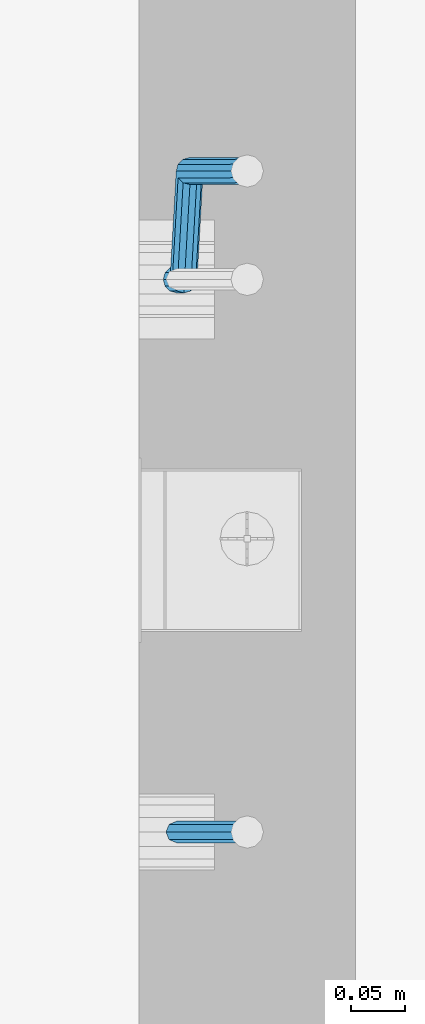
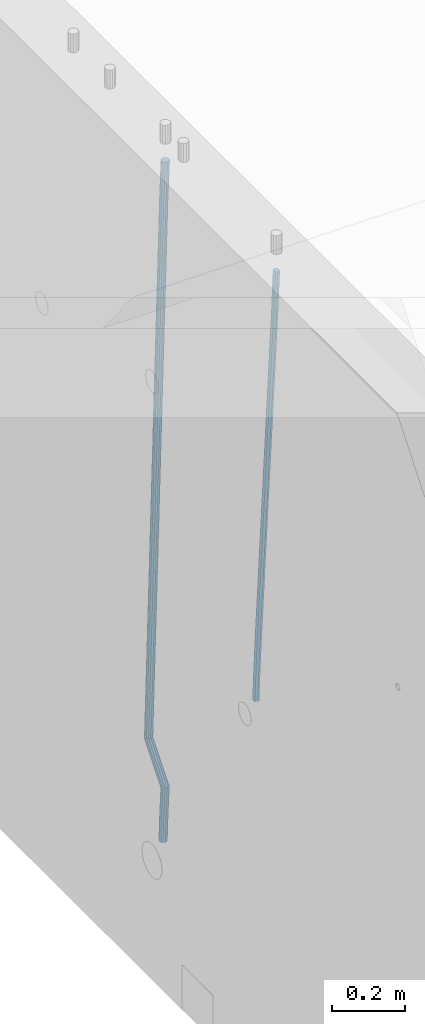
# One storey, part 103 of 350: 2 beams, 1 element without a shape of its own.
"""IFC2X3 building model written with IfcOpenShell, lengths in millimetres."""

from ifc_helpers import new_model, si_unit, frame, origin_with_axes, place, context, subcontext, project, spatial, faceted_brep, material, type_object, element, aggregate, save


model = new_model("IFC2X3")

# Units and contexts
model_context = context("Model", 3, precision=1e-05, world=origin_with_axes())
body_context = subcontext(model_context, "Body", "Model", "MODEL_VIEW")
ifc_project = project(units=[si_unit("LENGTHUNIT", "METRE", prefix="MILLI"), si_unit("AREAUNIT", "SQUARE_METRE"), si_unit("VOLUMEUNIT", "CUBIC_METRE"), si_unit("MASSUNIT", "GRAM", prefix="KILO"), si_unit("TIMEUNIT", "SECOND"), si_unit("PLANEANGLEUNIT", "RADIAN"), si_unit("SOLIDANGLEUNIT", "STERADIAN"), si_unit("THERMODYNAMICTEMPERATUREUNIT", "DEGREE_CELSIUS"), si_unit("LUMINOUSINTENSITYUNIT", "LUMEN")], contexts=[model_context])

# Site, building, storey
site_placement = place(None, origin_with_axes())
site = spatial("IfcSite", under=ifc_project, at=site_placement, CompositionType="ELEMENT")
building_placement = place(site_placement, origin_with_axes())
building = spatial("IfcBuilding", under=site, at=building_placement, CompositionType="ELEMENT")
storey_placement = place(building_placement, origin_with_axes())
storey = spatial("IfcBuildingStorey", under=building, at=storey_placement, Name="2", CompositionType="ELEMENT", Elevation=0.0)

# Assembly, beams
assembly_placement = place(storey_placement, origin_with_axes())
assembly = element("IfcElementAssembly", 1, at=assembly_placement, inside=storey, AssemblyPlace="NOTDEFINED", PredefinedType="REINFORCEMENT_UNIT")
ifc_material = material()
beam_type_1 = type_object("IfcBeamType", Name="D20", PredefinedType="NOTDEFINED")
beam_1_placement = place(assembly_placement, frame((21744.9999977209, 9994.99999999607, 85990.0), z_axis=(0.999642804629538, 0.000205762999925497, -0.0267249099901003), x_axis=(0.0267249109941254, -4.30000210532798e-08, 0.999642825779465)))
beam_1 = element("IfcBeam", 2, at=beam_1_placement, type_object=beam_type_1, material=ifc_material, Name="JM20", ObjectType="D20", context=body_context, shape_type="Brep", body=[
    faceted_brep([(0.0, -10.0, 0.0), (-4.19531716033816e-08, -7.07106781186667, -7.07106781187031), (60.4266690400545, -7.0710677960451, -7.07106780570757), (60.4266690441291, -9.99999998418934, 6.15546014159918e-09), (0.0, 0.0, -10.0), (60.426669036824, 1.58106558956206e-08, -9.99999999384454), (4.196772351861e-08, 7.07106781186303, -7.07106781186667), (60.4266690363438, 7.07106782768096, -7.07106780570757), (0.0, 10.0, 0.0), (60.4266690388904, 10.0000000158179, 6.15182216279209e-09), (4.196772351861e-08, 7.07106781185939, 7.07106781185939), (60.4266690429649, 7.07106782768096, 7.07106781802577), (0.0, 0.0, 10.0), (60.4266690461809, 1.58179318532348e-08, 10.0000000061555), (-4.19531716033816e-08, -7.07106781187031, 7.07106781185939), (60.4266690466611, -7.07106779605238, 7.07106781802213), (61.0378400410118, -7.07106779588503, -7.07106780564936), (60.991799419251, -9.99999998403655, 6.21366780251265e-09), (61.0569027789461, 1.5985278878361e-08, -9.99999999378269), (61.0378209396877, 7.07106782784831, -7.07106780564936), (60.9917724058905, 10.0000000159635, 6.21366780251265e-09), (60.9457317841297, 7.07106782781193, 7.0710678180767), (60.9266690461809, 1.59488990902901e-08, 10.0000000062028), (60.9457508854539, -7.07106779591413, 7.0710678180767), (61.6489592143771, -7.07106614513759, -7.06310863441468), (61.5568818710308, -9.9999984576425, 0.00735959856683621), (61.6870830769039, 1.71821739058942e-06, -9.99179257185824), (61.6489210170112, 7.07106947854481, -7.06310888312146), (61.556827851804, 10.0000015422847, 0.00735924683976918), (61.4647505084577, 7.07106922979438, 7.07782747982128), (61.4266266459163, 1.36643211590126e-06, 10.0065114172685), (61.464788705809, -7.07106639389531, 7.07782772852806), (176.543135720174, -7.07075579406956, -5.56673531796696), (176.451058376813, -9.99968810657447, 1.50373291501455), (176.581259582701, 0.000312069292704109, -8.49541925541052), (176.543097522794, 7.07137982961285, -5.56673556667374), (176.451004357587, 10.00031189336, 1.50373256329476), (176.35892701424, 7.07137958085514, 8.57420079627263), (176.320803151699, 0.000311717507429421, 11.5028847337162), (176.358965211621, -7.07075604281999, 8.57420104497578), (177.098753836006, -7.07075429323595, -5.55949898843028), (176.98362511232, -9.99968666800123, 1.510669025065), (177.146421932586, 0.000313595905026887, -8.48805862247536), (177.098706077581, 7.07138133041735, -5.55949936166144), (176.983557571715, 10.0003133318824, 1.51066849724157), (176.868428848029, 7.07138095712435, 8.58083651073321), (176.820760751449, 0.000313067976094317, 11.5093961447819), (176.868476606425, -7.07075466652896, 8.58083688396073), (177.654312950661, -7.07075204110879, -5.54863964998367), (177.516135294456, -9.99968450931192, 1.52107783331303), (177.711524267797, 0.000315886711177882, -8.47701274570863), (177.654255632195, 7.07138358250813, -5.54864021007961), (177.516054233929, 10.0003154905207, 1.5210770412159), (177.377876577739, 7.0713830223176, 8.59079452451624), (177.320665260588, 0.000315094497636892, 11.5191676202448), (177.377933896176, -7.07075260129932, 8.59079508461218), (299.599458226279, -7.07025770011387, -3.16501643125957), (299.461280570089, -9.99919016831518, 3.90470105203713), (299.65666954343, 0.000810227711554035, -6.09338952698454), (299.599400907857, 7.07187792350123, -3.16501699135551), (299.461199509577, 10.0008098315193, 3.90470025994), (299.323021853372, 7.07187736331798, 10.9744177432367), (299.265810536235, 0.000809435492556077, 13.9027908389617), (299.323079171809, -7.07025826029712, 10.9744183033363), (300.117505425049, -7.07025560005422, -3.15489032637561), (299.971788958996, -9.99918809853989, 3.91467979818117), (300.177827776904, 0.000812340382253751, -6.0832026116841), (300.117445104319, 7.07188002354815, -3.15489094515215), (299.971753863239, 10.0008119014747, 3.91467990454839), (299.826037397244, 7.07187940244148, 10.9842500291161), (299.765715045374, 0.000811462005003705, 13.9125623144282), (299.826097717974, -7.07025622116089, 10.9842506478926), (300.635529927473, -7.07025328000054, -3.14366299205358), (300.482325191449, -9.99918581231213, 3.92574478310053), (300.69896317774, 0.000814674367575208, -6.07190785373314), (300.635466604566, 7.07188234358546, -3.14366367590264), (300.482235639342, 10.000814187486, 3.92574381599843), (300.329030903304, 7.07188165517618, 10.9951515911598), (300.265597653051, 0.000813700806247653, 13.9233964528321), (300.329094226225, -7.07025396841345, 10.9951522750052), (1294.72134140272, -7.06580111335825, 18.4015220180045), (1294.5681366667, -9.99473364566802, 25.4709297931586), (1294.78477465297, 0.00526684101168939, 15.4732771563286), (1294.7212780798, 7.07633451023139, 18.4015213341554), (1294.56804711456, 10.0052663541301, 25.4709288260528), (1294.41484237854, 7.07633382181848, 32.5403366012142), (1294.35140912827, 0.00526586744854285, 35.4685814628901), (1294.41490570146, -7.06580180177116, 32.5403372850597), (1295.22122401037, -7.065798874557, 18.4123561564047), (1295.07847764336, -9.99473136002962, 25.4819905996155), (1295.31851894651, 0.00526923146571789, 15.4848451914186), (1295.31336839774, 7.07633716199962, 18.4143539239521), (1295.20878948565, 10.005269223795, 25.4848158695786), (1295.06604311864, 7.07633673832242, 32.5544503127894), (1294.96874818249, 0.00526863229970331, 35.4819612777756), (1294.97389873129, -7.0657992982342, 32.5524525452383), (1295.72113723878, -7.07231784537726, 18.4190095076701), (1295.5888498814, -10.0013867184771, 25.4887831499691), (1295.85229593501, -0.00169132971677755, 15.4919492358822), (1295.90549498468, 7.06861571010995, 18.4222345439302), (1295.84957110598, 9.99691330030873, 25.4933440399909), (1295.71728374861, 7.06784442721073, 32.5631176822862), (1295.58612505237, -0.00278208844792971, 35.4901779540742), (1295.53292600272, -7.07308912827466, 32.5598926460261), (1317.55191410908, -7.35699564410061, 18.7095555837295), (1317.41962675171, -10.2860645171968, 25.7793292260321), (1317.68307280532, -0.28636912843649, 15.7824953119416), (1317.73627185497, 6.7839379113866, 18.7127806199969), (1317.68034797629, 9.71223550158902, 25.783890116054), (1317.54806061891, 6.7831666284892, 32.8536637583529), (1317.41690192268, -0.2874598871731, 35.7807240301408), (1317.363702873, -7.35776692699619, 32.8504387220928), (1318.18734857353, -7.36528183957671, 18.7180125887826), (1318.07971594617, -10.2946722153993, 25.7881143611849), (1318.26138049197, -0.293910379039517, 15.7901920160075), (1318.25844480767, 6.77712866920592, 18.7197302261993), (1318.18026120469, 9.70571653076877, 25.7905434673194), (1318.07262857731, 6.7763261549444, 32.8606452397216), (1317.99859665887, -0.295045305590975, 35.7884658124931), (1318.00153234317, -7.36608435383823, 32.8589276023013), (1318.82283685768, -7.36340599946743, 18.7262747478708), (1318.73986089561, -10.2927036625733, 25.7967042930031), (1318.83973741514, -0.292212851787554, 15.7976939308101), (1318.78066245062, 6.77866673671087, 18.7264847659571), (1318.68021727716, 9.70720740099387, 25.7970013034283), (1318.59724131509, 6.77790973788615, 32.867430848557), (1318.58034075763, -0.293283409790092, 35.7960116656141), (1318.63941572215, -7.36416299828852, 32.8672208304743), (1418.8436227144, -7.06514386045455, 20.0236527734232), (1418.76064675233, -9.99444152356227, 27.0940823185556), (1418.86052327185, 0.00604928722168552, 17.0950719563662), (1418.80144830733, 7.07692887572193, 20.0238627915096), (1418.70100313389, 10.0054695400049, 27.0943793289771), (1418.61802717182, 7.07617187689721, 34.1648088741131), (1418.60112661435, 0.00497872922096576, 37.0933896911702), (1418.66020157887, -7.06590085927746, 34.1645988560231)], [[[0, 1, 2, 3]], [[1, 4, 5, 2]], [[4, 6, 7, 5]], [[6, 8, 9, 7]], [[8, 10, 11, 9]], [[10, 12, 13, 11]], [[12, 14, 15, 13]], [[14, 0, 3, 15]], [[14, 12, 10, 8, 6, 4, 1, 0]], [[3, 2, 16, 17]], [[2, 5, 18, 16]], [[5, 7, 19, 18]], [[7, 9, 20, 19]], [[9, 11, 21, 20]], [[11, 13, 22, 21]], [[13, 15, 23, 22]], [[15, 3, 17, 23]], [[17, 16, 24, 25]], [[16, 18, 26, 24]], [[18, 19, 27, 26]], [[19, 20, 28, 27]], [[20, 21, 29, 28]], [[21, 22, 30, 29]], [[22, 23, 31, 30]], [[23, 17, 25, 31]], [[25, 24, 32, 33]], [[24, 26, 34, 32]], [[26, 27, 35, 34]], [[27, 28, 36, 35]], [[28, 29, 37, 36]], [[29, 30, 38, 37]], [[30, 31, 39, 38]], [[31, 25, 33, 39]], [[33, 32, 40, 41]], [[32, 34, 42, 40]], [[34, 35, 43, 42]], [[35, 36, 44, 43]], [[36, 37, 45, 44]], [[37, 38, 46, 45]], [[38, 39, 47, 46]], [[39, 33, 41, 47]], [[41, 40, 48, 49]], [[40, 42, 50, 48]], [[42, 43, 51, 50]], [[43, 44, 52, 51]], [[44, 45, 53, 52]], [[45, 46, 54, 53]], [[46, 47, 55, 54]], [[47, 41, 49, 55]], [[49, 48, 56, 57]], [[48, 50, 58, 56]], [[50, 51, 59, 58]], [[51, 52, 60, 59]], [[52, 53, 61, 60]], [[53, 54, 62, 61]], [[54, 55, 63, 62]], [[55, 49, 57, 63]], [[57, 56, 64, 65]], [[56, 58, 66, 64]], [[58, 59, 67, 66]], [[59, 60, 68, 67]], [[60, 61, 69, 68]], [[61, 62, 70, 69]], [[62, 63, 71, 70]], [[63, 57, 65, 71]], [[65, 64, 72, 73]], [[64, 66, 74, 72]], [[66, 67, 75, 74]], [[67, 68, 76, 75]], [[68, 69, 77, 76]], [[69, 70, 78, 77]], [[70, 71, 79, 78]], [[71, 65, 73, 79]], [[73, 72, 80, 81]], [[72, 74, 82, 80]], [[74, 75, 83, 82]], [[75, 76, 84, 83]], [[76, 77, 85, 84]], [[77, 78, 86, 85]], [[78, 79, 87, 86]], [[79, 73, 81, 87]], [[81, 80, 88, 89]], [[80, 82, 90, 88]], [[82, 83, 91, 90]], [[83, 84, 92, 91]], [[84, 85, 93, 92]], [[85, 86, 94, 93]], [[86, 87, 95, 94]], [[87, 81, 89, 95]], [[89, 88, 96, 97]], [[88, 90, 98, 96]], [[90, 91, 99, 98]], [[91, 92, 100, 99]], [[92, 93, 101, 100]], [[93, 94, 102, 101]], [[94, 95, 103, 102]], [[95, 89, 97, 103]], [[97, 96, 104, 105]], [[96, 98, 106, 104]], [[98, 99, 107, 106]], [[99, 100, 108, 107]], [[100, 101, 109, 108]], [[101, 102, 110, 109]], [[102, 103, 111, 110]], [[103, 97, 105, 111]], [[105, 104, 112, 113]], [[104, 106, 114, 112]], [[106, 107, 115, 114]], [[107, 108, 116, 115]], [[108, 109, 117, 116]], [[109, 110, 118, 117]], [[110, 111, 119, 118]], [[111, 105, 113, 119]], [[113, 112, 120, 121]], [[112, 114, 122, 120]], [[114, 115, 123, 122]], [[115, 116, 124, 123]], [[116, 117, 125, 124]], [[117, 118, 126, 125]], [[118, 119, 127, 126]], [[119, 113, 121, 127]], [[121, 120, 128, 129]], [[120, 122, 130, 128]], [[122, 123, 131, 130]], [[123, 124, 132, 131]], [[124, 125, 133, 132]], [[125, 126, 134, 133]], [[126, 127, 135, 134]], [[127, 121, 129, 135]], [[130, 131, 132, 133, 134, 135, 129, 128]]]),
])
beam_type_2 = type_object("IfcBeamType", Name="D25", PredefinedType="NOTDEFINED")
beam_2_placement = place(assembly_placement, frame((21744.9999977209, 10504.9999999961, 85210.0), z_axis=(0.999642804629538, 0.000205762999925497, -0.0267249099901003), x_axis=(0.0267249109941254, -4.30000210532798e-08, 0.999642825779465)))
beam_2 = element("IfcBeam", 3, at=beam_2_placement, type_object=beam_type_2, material=ifc_material, Name="JM25", ObjectType="D25", context=body_context, shape_type="Brep", body=[
    faceted_brep([(-7.41420080885291e-08, -12.5, -3.63797880709171e-12), (-6.42030499875546e-08, -10.8253175473074, -6.25000000000364), (60.4103898235917, -10.8253175318459, -6.2499999938409), (60.4103898269532, -12.4999999845422, 6.16273609921336e-09), (-3.70782800018787e-08, -6.25000000000364, -10.8253175473074), (60.4103898202884, -6.24999998454587, -10.8253175411446), (-1.45519152283669e-11, -3.63797880709171e-12, -12.5), (60.4103898179019, 1.54577719513327e-08, -12.4999999938373), (3.70637280866504e-08, 6.25, -10.8253175473074), (60.410389817087, 6.25000001545777, -10.825317541141), (6.42030499875546e-08, 10.8253175473001, -6.25000000000364), (60.410389818062, 10.8253175627578, -6.24999999383726), (7.41420080885291e-08, 12.4999999999927, 0.0), (60.4103898205503, 12.5000000154541, 6.16273609921336e-09), (6.42176019027829e-08, 10.8253175473001, 6.24999999999636), (60.4103898238973, 10.8253175627651, 6.2500000061591), (3.70928319171071e-08, 6.24999999999636, 10.8253175473037), (60.4103898272151, 6.25000001546141, 10.8253175534664), (1.45519152283669e-11, -3.63797880709171e-12, 12.4999999999964), (60.4103898296162, 1.54541339725256e-08, 12.5000000061591), (-3.7049176171422e-08, -6.25000000000364, 10.8253175473001), (60.4103898304165, -6.24999998454587, 10.8253175534701), (-6.41884980723262e-08, -10.8253175473074, 6.25), (60.4103898294561, -10.8253175318459, 6.25000000616637), (61.0324985728803, -10.8253175316895, -6.24999999377542), (60.991802792938, -12.4999999843931, 6.22458173893392e-09), (61.0622854283865, -6.24999998437852, -10.8253175410755), (61.0731819955545, 1.5628756955266e-08, -12.4999999937718), (61.0622685480339, 6.25000001562512, -10.8253175410791), (61.032469335245, 10.8253175629216, -6.24999999377178), (60.9917690322181, 12.5000000156033, 6.22458173893392e-09), (60.9510732522613, 10.8253175629034, 6.25000000621731), (60.9212863967696, 6.25000001558874, 10.8253175535247), (60.9103898296162, 1.55814632307738e-08, 12.5000000062137), (60.9213032771368, -6.24999998441126, 10.8253175535174), (60.9511024898966, -10.8253175317113, 6.25000000621731), (61.6545545670233, -10.8253158516927, -6.24189838219536), (61.573166454793, -12.499998414296, 0.00757164385504439), (61.7141257553885, -6.24999822394238, -10.8168280205282), (61.7359179680789, 1.80548886419274e-06, -12.491368569139), (61.7140919992817, 6.25000177601396, -10.8168282403167), (61.6544960997562, 10.8253192428383, -6.2418987628771), (61.5730989426083, 12.5000015856094, 0.0075712042817031), (61.4917108303925, 10.8253190230062, 6.25704123032847), (61.4321396420273, 6.25000139525582, 10.8319708686649), (61.4103474293224, 1.36582457344048e-06, 12.5065114172721), (61.4321733981196, -6.24999860470052, 10.8319710884571), (61.4917692976451, -10.8253160715249, 6.25704161101385), (171.496768358847, -10.8250191983461, -4.81132145704032), (171.415380246617, -12.4997017609512, 1.43814856900644), (171.556339547184, -6.24970157059397, -9.38625109538043), (171.578131759845, 0.000298458835459314, -11.0607916439913), (171.556305791062, 6.25029842936056, -9.38625131517256), (171.496709891493, 10.8256158961849, -4.8113218377257), (171.415312734331, 12.5002982389578, 1.43814812942583), (171.333924622115, 10.8256156763564, 7.68761815547623), (171.274353433779, 6.2502980486006, 12.2625477938163), (171.252561221118, 0.000298019174806541, 13.9370883424199), (171.274387189915, -6.24970195135211, 12.2625480136048), (171.333983089469, -10.8250194181783, 7.68761853615797), (172.716738696545, -10.8250159035488, -4.79543265296888), (171.915337846367, -12.4997004107063, 1.4446599800649), (174.661439267307, -6.24969318458898, -9.34581050468478), (177.228358611188, 0.000313718517645611, -10.9872035044536), (179.729692762965, 6.25032050338996, -9.27980172353637), (181.495211256653, 10.8256428993391, -4.681102090286), (182.051844837653, 12.5003269652552, 1.57667754235081), (181.250443987461, 10.8256424580995, 7.81677017537731), (179.305743416699, 6.25031973913974, 12.3671480270932), (176.738824072818, 0.000312836033117492, 14.0085410268657), (174.237489921055, -6.24969394883919, 12.3011392459521), (172.471971427352, -10.8250163447901, 7.70243961269443), (173.591912530683, -11.6747326915593, -4.77028868389971), (172.273993951298, -12.8479239311091, 1.45496426209138), (176.888954103924, -8.41241409598842, -9.2818134312256), (181.281679044056, -3.93510377752864, -10.8707505672064), (185.593060250772, 0.557506579716573, -9.1113456694402), (188.667866611489, 3.86162565862105, -4.4750298594372), (189.682206244979, 5.09191742029725, 1.79589978565855), (188.364287665579, 3.91872618074558, 8.021152731646), (185.067246092338, 0.656407585174748, 12.5326774789683), (180.674521152207, -3.8209027332814, 14.1216146149563), (176.36313994549, -8.31351309053025, 12.3622097171901), (173.288333584787, -11.6176321694347, 7.72589390718713), (268.598404954697, -103.917677387682, -2.04072775141685), (267.280486375297, -105.090868627234, 4.18452519456696), (271.895446527924, -100.65535879211, -6.55225249874275), (276.288171468055, -96.1780484736537, -8.1411896347272), (280.599552674787, -91.6854381164067, -6.38178473695734), (283.674359035489, -88.3813190374985, -1.74546892695435), (284.688698668993, -87.1510272758242, 4.52546071813777), (283.370780089594, -88.324218515374, 10.7507136641289), (280.073738516352, -91.5865371109467, 15.2622384114547), (275.681013576221, -96.0638474294028, 16.8511755474319), (271.369632369504, -100.55645778665, 15.0917706496657), (268.294826008787, -103.860576865558, 10.4554548396627), (275.678171584295, -110.79150784929, -1.83732423750553), (274.910466417045, -112.498907899753, 4.40373648114473), (277.598256296449, -106.192285297533, -6.38840930916194), (280.156235405506, -99.933598213036, -8.0300591641826), (282.666700474903, -93.69245674577, -6.32239504965401), (284.456974416695, -89.1411697117383, -1.72298418601713), (285.047354773909, -87.4992507962288, 4.53576500016788), (284.279649606659, -89.2066508466924, 10.7768257188254), (282.359564894505, -93.805873398449, 15.3279107904782), (279.801585785448, -100.064560482946, 16.9695606454916), (277.291120716036, -106.30570195021, 15.2618965309666), (275.500846774259, -110.856988984244, 10.6624856673297), (285.548025314434, -110.791507724489, -1.83628607281935), (285.547368862506, -112.498907765255, 4.40485532817547), (285.548503982704, -106.192285197007, -6.38757305904073), (285.548676608552, -99.933598144853, -8.02949195800102), (285.548496937015, -93.6924567093301, -6.32209192668597), (285.548013110951, -89.1411696979412, -1.72286942465507), (285.547354771159, -87.499250789906, 4.53581759287408), (285.546698319231, -89.2066508306707, 10.7769589938689), (285.546219650962, -93.8058733581547, 15.3282459800866), (285.546047025127, -100.06456041031, 16.9701648790469), (285.54622669665, -106.305701845829, 15.2627648477392), (285.546710522714, -110.856988857218, 10.6635423457046), (2074.25333672202, -110.791485106987, -1.64814035737072), (2074.2526802701, -112.498885147752, 4.59300104362046), (2074.25381539032, -106.192262579505, -6.19942734358847), (2074.25398801616, -99.9335755273514, -7.84134624254875), (2074.25380834464, -93.6924340918322, -6.13394621124462), (2074.25332451856, -89.1411470804433, -1.53472370920645), (2074.25266617877, -87.499228172408, 4.72396330832635), (2074.25200972684, -89.2066282131709, 10.9651047093175), (2074.25153105859, -93.8058507406568, 15.5163916955389), (2074.25135843272, -100.06453779281, 17.1583105944992), (2074.25153810425, -106.305679228328, 15.4509105631842), (2074.25202193031, -110.856966239717, 10.8516880611533), (2074.83696830293, -110.791485099611, -1.64807896783896), (2074.78398067175, -112.498885141034, 4.59305692867565), (2074.89747594834, -106.192262571365, -6.1993596398861), (2074.94929063322, -99.9335755185584, -7.84127310686017), (2074.97852865464, -93.6924340826681, -6.13386998122951), (2074.97735570835, -89.1411470712865, -1.5346475516817), (2074.94608608437, -87.4992281636405, 4.72403624598519), (2074.89309845318, -89.2066282050637, 10.9651721425071), (2074.8325908078, -93.8058507333099, 15.5164528145506), (2074.78077612289, -100.064537786115, 17.158366281521), (2074.75153810147, -106.305679222007, 15.4509631558976), (2074.75271104777, -110.856966233388, 10.8517407263462), (2075.42049860313, -110.799094351876, -1.64031275624438), (2075.315188874, -112.505812111609, 4.60012678485873), (2075.5410248085, -106.200654467422, -6.19079464056631), (2075.64447259072, -99.9426407117207, -7.8320209220401), (2075.70312320006, -93.7018828168402, -6.1242263439417), (2075.70126125314, -89.1505868208715, -1.52501308430874), (2075.63938565711, -87.5082688104485, 4.73326337811886), (2075.53407592798, -89.2149865701776, 10.9737029192256), (2075.41354972261, -93.8134264546352, 15.5241848035512), (2075.31010194038, -100.071440210337, 17.1654110850213), (2075.25145133105, -106.312198105215, 15.4576165069193), (2075.25331327796, -110.863494101184, 10.85840324729), (2097.1945896636, -111.08302913941, -1.35052112331687), (2097.08927993447, -112.789746899141, 4.88991841778625), (2097.31511586897, -106.484589254955, -5.90100300764971), (2097.41856365118, -100.226575499253, -7.54222928911986), (2097.47721426054, -93.9858176043745, -5.83443471101782), (2097.4753523136, -89.4345216084039, -1.23522145138486), (2097.41347671759, -87.7922035979809, 5.02305501104274), (2097.30816698846, -89.4989213577119, 11.2634945521422), (2097.18764078306, -94.0973612421694, 15.8139764364751), (2097.08419300086, -100.355374997869, 17.4552027179489), (2097.02554239152, -106.596132892748, 15.7474081398468), (2097.02740433844, -111.147428888718, 11.1481948802139), (2097.87997251838, -111.091966551987, -1.34139935488201), (2097.78938683082, -112.798876313653, 4.89923614866711), (2097.96289911156, -106.493036367479, -5.89238165288771), (2098.01594649666, -100.234365389122, -7.5342787138361), (2098.02490066971, -93.9929594512505, -5.82714554618724), (2097.98736236728, -89.4411982345555, -1.22840710358651), (2097.91338994715, -87.7987224811914, 5.02970836206805), (2097.82280425957, -89.5056322428572, 11.2703438656135), (2097.7398776664, -94.1045624273629, 15.8213261636229), (2097.68683028129, -100.363233405722, 17.4632232245676), (2097.67787610824, -106.604639343592, 15.7560900569224), (2097.71541441069, -111.156400560287, 11.1573516143217), (2098.56541322041, -111.089943792393, -1.33247210230547), (2098.48955268873, -112.796788628493, 4.90836015004606), (2098.61073725206, -106.491141065437, -5.88395763208973), (2098.61338024602, -100.23262592446, -7.5265295672325), (2098.57263401416, -93.9913624473083, -5.82006208420717), (2098.49941647641, -89.4396921424323, -1.22180176699476), (2098.4133462129, -87.7972313922346, 5.03615124581847), (2098.33748568122, -89.5040762283334, 11.2769834981773), (2098.29216164956, -94.1028789552893, 15.8284690279543), (2098.28951865561, -100.361394096264, 17.4710409631007), (2098.33026488747, -106.602657573418, 15.7645734800717), (2098.4034824252, -111.154327878296, 11.1663131628593), (2198.56618852627, -110.791740651814, -0.0353536246875592), (2198.49032799456, -112.498585487912, 6.20547862766762), (2198.61151255792, -106.19293792486, -4.58683915447182), (2198.61415555187, -99.9344227838828, -6.22941108961459), (2198.57340932002, -93.6931593067293, -4.52294360658198), (2198.50019178227, -89.1414890018532, 0.0753167106267938), (2198.41412151874, -87.4990282516574, 6.33326972344003), (2198.33826098708, -89.2058730877579, 12.5741019757952), (2198.29293695542, -93.8046758147102, 17.1255875055758), (2198.29029396146, -100.063190955687, 18.768159440715), (2198.33104019333, -106.30445443284, 17.0616919576896), (2198.40425773106, -110.856124737718, 12.4634316404808)], [[[0, 1, 2, 3]], [[1, 4, 5, 2]], [[4, 6, 7, 5]], [[6, 8, 9, 7]], [[8, 10, 11, 9]], [[10, 12, 13, 11]], [[12, 14, 15, 13]], [[14, 16, 17, 15]], [[16, 18, 19, 17]], [[18, 20, 21, 19]], [[20, 22, 23, 21]], [[22, 0, 3, 23]], [[22, 20, 18, 16, 14, 12, 10, 8, 6, 4, 1, 0]], [[3, 2, 24, 25]], [[2, 5, 26, 24]], [[5, 7, 27, 26]], [[7, 9, 28, 27]], [[9, 11, 29, 28]], [[11, 13, 30, 29]], [[13, 15, 31, 30]], [[15, 17, 32, 31]], [[17, 19, 33, 32]], [[19, 21, 34, 33]], [[21, 23, 35, 34]], [[23, 3, 25, 35]], [[25, 24, 36, 37]], [[24, 26, 38, 36]], [[26, 27, 39, 38]], [[27, 28, 40, 39]], [[28, 29, 41, 40]], [[29, 30, 42, 41]], [[30, 31, 43, 42]], [[31, 32, 44, 43]], [[32, 33, 45, 44]], [[33, 34, 46, 45]], [[34, 35, 47, 46]], [[35, 25, 37, 47]], [[37, 36, 48, 49]], [[36, 38, 50, 48]], [[38, 39, 51, 50]], [[39, 40, 52, 51]], [[40, 41, 53, 52]], [[41, 42, 54, 53]], [[42, 43, 55, 54]], [[43, 44, 56, 55]], [[44, 45, 57, 56]], [[45, 46, 58, 57]], [[46, 47, 59, 58]], [[47, 37, 49, 59]], [[49, 48, 60, 61]], [[48, 50, 62, 60]], [[50, 51, 63, 62]], [[51, 52, 64, 63]], [[52, 53, 65, 64]], [[53, 54, 66, 65]], [[54, 55, 67, 66]], [[55, 56, 68, 67]], [[56, 57, 69, 68]], [[57, 58, 70, 69]], [[58, 59, 71, 70]], [[59, 49, 61, 71]], [[61, 60, 72, 73]], [[60, 62, 74, 72]], [[62, 63, 75, 74]], [[63, 64, 76, 75]], [[64, 65, 77, 76]], [[65, 66, 78, 77]], [[66, 67, 79, 78]], [[67, 68, 80, 79]], [[68, 69, 81, 80]], [[69, 70, 82, 81]], [[70, 71, 83, 82]], [[71, 61, 73, 83]], [[73, 72, 84, 85]], [[72, 74, 86, 84]], [[74, 75, 87, 86]], [[75, 76, 88, 87]], [[76, 77, 89, 88]], [[77, 78, 90, 89]], [[78, 79, 91, 90]], [[79, 80, 92, 91]], [[80, 81, 93, 92]], [[81, 82, 94, 93]], [[82, 83, 95, 94]], [[83, 73, 85, 95]], [[85, 84, 96, 97]], [[84, 86, 98, 96]], [[86, 87, 99, 98]], [[87, 88, 100, 99]], [[88, 89, 101, 100]], [[89, 90, 102, 101]], [[90, 91, 103, 102]], [[91, 92, 104, 103]], [[92, 93, 105, 104]], [[93, 94, 106, 105]], [[94, 95, 107, 106]], [[95, 85, 97, 107]], [[97, 96, 108, 109]], [[96, 98, 110, 108]], [[98, 99, 111, 110]], [[99, 100, 112, 111]], [[100, 101, 113, 112]], [[101, 102, 114, 113]], [[102, 103, 115, 114]], [[103, 104, 116, 115]], [[104, 105, 117, 116]], [[105, 106, 118, 117]], [[106, 107, 119, 118]], [[107, 97, 109, 119]], [[109, 108, 120, 121]], [[108, 110, 122, 120]], [[110, 111, 123, 122]], [[111, 112, 124, 123]], [[112, 113, 125, 124]], [[113, 114, 126, 125]], [[114, 115, 127, 126]], [[115, 116, 128, 127]], [[116, 117, 129, 128]], [[117, 118, 130, 129]], [[118, 119, 131, 130]], [[119, 109, 121, 131]], [[121, 120, 132, 133]], [[120, 122, 134, 132]], [[122, 123, 135, 134]], [[123, 124, 136, 135]], [[124, 125, 137, 136]], [[125, 126, 138, 137]], [[126, 127, 139, 138]], [[127, 128, 140, 139]], [[128, 129, 141, 140]], [[129, 130, 142, 141]], [[130, 131, 143, 142]], [[131, 121, 133, 143]], [[133, 132, 144, 145]], [[132, 134, 146, 144]], [[134, 135, 147, 146]], [[135, 136, 148, 147]], [[136, 137, 149, 148]], [[137, 138, 150, 149]], [[138, 139, 151, 150]], [[139, 140, 152, 151]], [[140, 141, 153, 152]], [[141, 142, 154, 153]], [[142, 143, 155, 154]], [[143, 133, 145, 155]], [[145, 144, 156, 157]], [[144, 146, 158, 156]], [[146, 147, 159, 158]], [[147, 148, 160, 159]], [[148, 149, 161, 160]], [[149, 150, 162, 161]], [[150, 151, 163, 162]], [[151, 152, 164, 163]], [[152, 153, 165, 164]], [[153, 154, 166, 165]], [[154, 155, 167, 166]], [[155, 145, 157, 167]], [[157, 156, 168, 169]], [[156, 158, 170, 168]], [[158, 159, 171, 170]], [[159, 160, 172, 171]], [[160, 161, 173, 172]], [[161, 162, 174, 173]], [[162, 163, 175, 174]], [[163, 164, 176, 175]], [[164, 165, 177, 176]], [[165, 166, 178, 177]], [[166, 167, 179, 178]], [[167, 157, 169, 179]], [[169, 168, 180, 181]], [[168, 170, 182, 180]], [[170, 171, 183, 182]], [[171, 172, 184, 183]], [[172, 173, 185, 184]], [[173, 174, 186, 185]], [[174, 175, 187, 186]], [[175, 176, 188, 187]], [[176, 177, 189, 188]], [[177, 178, 190, 189]], [[178, 179, 191, 190]], [[179, 169, 181, 191]], [[181, 180, 192, 193]], [[180, 182, 194, 192]], [[182, 183, 195, 194]], [[183, 184, 196, 195]], [[184, 185, 197, 196]], [[185, 186, 198, 197]], [[186, 187, 199, 198]], [[187, 188, 200, 199]], [[188, 189, 201, 200]], [[189, 190, 202, 201]], [[190, 191, 203, 202]], [[191, 181, 193, 203]], [[194, 195, 196, 197, 198, 199, 200, 201, 202, 203, 193, 192]]]),
])
aggregate(assembly, [beam_2, beam_1])

save(model, "model.ifc")
